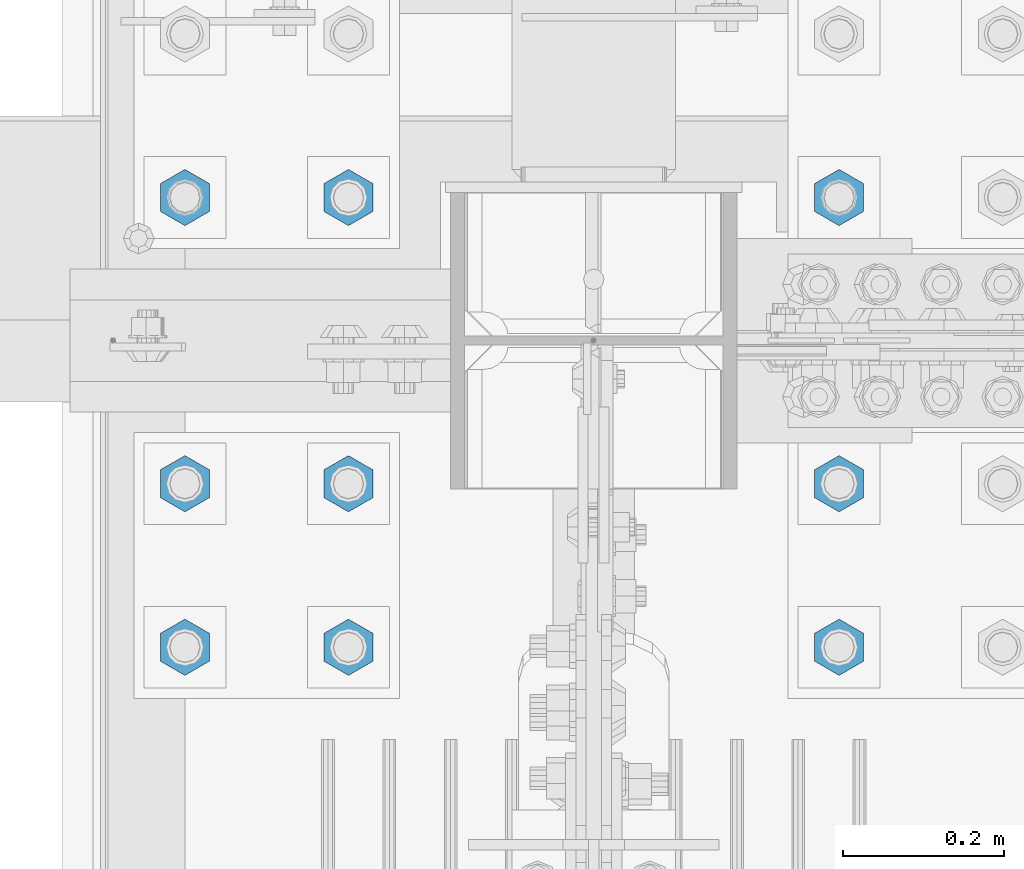
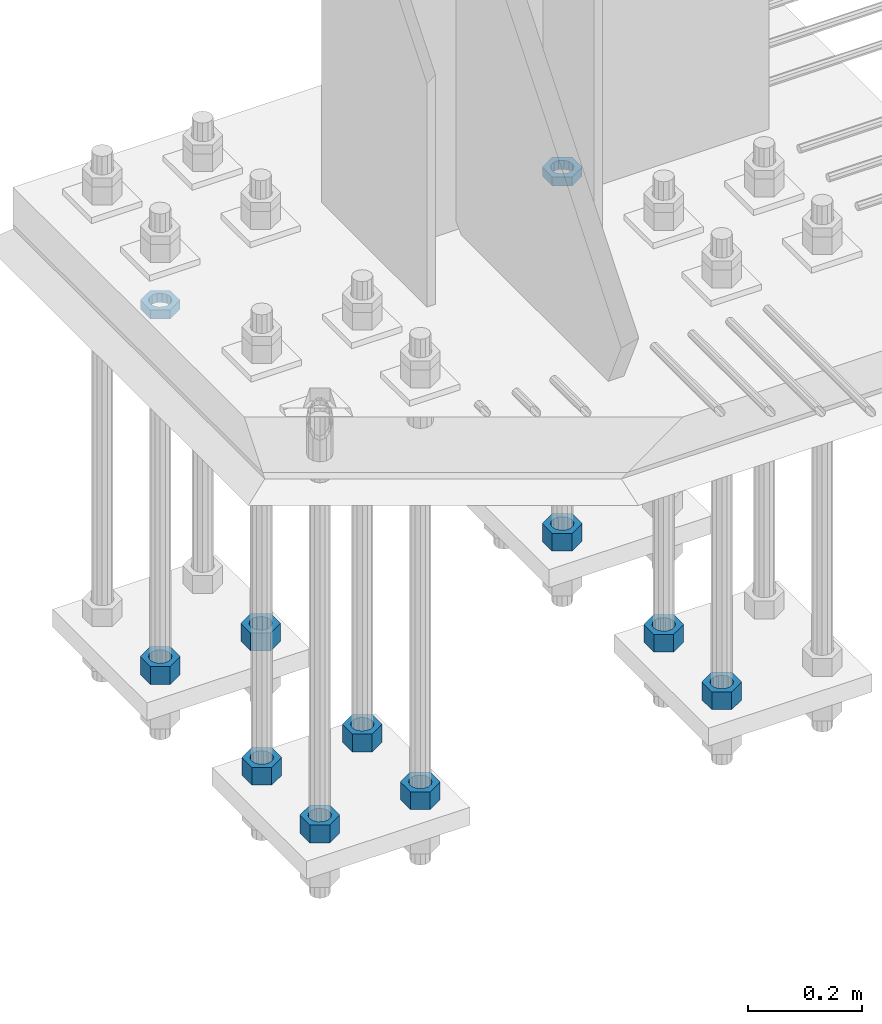
# One storey, part 2927 of 3843: 11 beams, 1 element without a shape of its own.
"""IFC2X3 building model written with IfcOpenShell, lengths in millimetres."""

from ifc_helpers import new_model, si_unit, frame, origin_with_axes, place, context, subcontext, project, spatial, faceted_brep, material, type_object, element, aggregate, save


model = new_model("IFC2X3")

# Units and contexts
model_context = context("Model", 3, precision=1e-05, world=origin_with_axes())
body_context = subcontext(model_context, "Body", "Model", "MODEL_VIEW")
ifc_project = project(units=[si_unit("LENGTHUNIT", "METRE", prefix="MILLI"), si_unit("AREAUNIT", "SQUARE_METRE"), si_unit("VOLUMEUNIT", "CUBIC_METRE"), si_unit("MASSUNIT", "GRAM", prefix="KILO"), si_unit("TIMEUNIT", "SECOND"), si_unit("PLANEANGLEUNIT", "RADIAN"), si_unit("SOLIDANGLEUNIT", "STERADIAN"), si_unit("THERMODYNAMICTEMPERATUREUNIT", "DEGREE_CELSIUS"), si_unit("LUMINOUSINTENSITYUNIT", "LUMEN")], contexts=[model_context])

# Site, building, storey
site_placement = place(None, origin_with_axes())
site = spatial("IfcSite", under=ifc_project, at=site_placement, CompositionType="ELEMENT")
building_placement = place(site_placement, origin_with_axes())
building = spatial("IfcBuilding", under=site, at=building_placement, Name="Undefined", CompositionType="ELEMENT")
storey_placement = place(building_placement, origin_with_axes())
storey = spatial("IfcBuildingStorey", under=building, at=storey_placement, Name="Undefined", CompositionType="ELEMENT", Elevation=0.0)

# Assembly, beams
assembly_placement = place(storey_placement, origin_with_axes())
assembly = element("IfcElementAssembly", 1, at=assembly_placement, inside=storey, Name="TEMPLATE", AssemblyPlace="NOTDEFINED", PredefinedType="RIGID_FRAME")
ifc_material = material(Name="STEEL/A572-50")
beam_type_1 = type_object("IfcBeamType", Name="1-1/2_HEAVY_HEX_NUT", PredefinedType="NOTDEFINED")
beam_1_placement = place(assembly_placement, frame((77317.6, 104736.9, 28841.7000015259), z_axis=(-1.0, 0.0, 0.0), x_axis=(0.0, 0.0, -1.0)))
beam_1 = element("IfcBeam", 2, at=beam_1_placement, type_object=beam_type_1, material=ifc_material, Name="NUT", ObjectType="1-1/2_HEAVY_HEX_NUT", context=body_context, shape_type="Brep", body=[
    faceted_brep([(0.0, -34.9199981689453, 0.0), (0.0, -17.4599990844727, -30.25), (38.0999999999985, -17.4599990844727, -30.25), (38.0999999999985, -34.9199981689453, 0.0), (0.0, 17.4599990844727, -30.25), (38.0999999999985, 17.4599990844727, -30.25), (0.0, 34.9199981689453, 0.0), (38.0999999999985, 34.9199981689453, 0.0), (0.0, 17.4599990844727, 30.25), (38.0999999999985, 17.4599990844727, 30.25), (0.0, -17.4599990844727, 30.25), (38.0999999999985, -17.4599990844727, 30.25), (0.0, 0.0, 20.6399993896484), (0.0, 8.9553601105581, 18.5959968835959), (38.0999999999985, 8.9553601105581, 18.5959968835959), (38.0999999999985, 0.0, 20.6399993896484), (0.0, 16.1370013209525, 12.8688291298167), (38.0999999999985, 16.1370013209525, 12.8688291298167), (0.0, 20.1225115123816, 4.59283194104501), (38.0999999999985, 20.1225115123816, 4.59283194104501), (0.0, 20.1225115123816, -4.59283194104501), (38.0999999999985, 20.1225115123816, -4.59283194104501), (0.0, 16.1370013209525, -12.8688291298167), (38.0999999999985, 16.1370013209525, -12.8688291298167), (0.0, 8.9553601105581, -18.5959968835959), (38.0999999999985, 8.9553601105581, -18.5959968835959), (0.0, 0.0, -20.6399993896484), (38.0999999999985, 0.0, -20.6399993896484), (0.0, -8.9553601105581, -18.5959968835959), (38.0999999999985, -8.9553601105581, -18.5959968835959), (0.0, -16.1370013209525, -12.8688291298167), (38.0999999999985, -16.1370013209525, -12.8688291298167), (0.0, -20.1225115123816, -4.59283194104501), (38.0999999999985, -20.1225115123816, -4.59283194104501), (0.0, -20.1225115123816, 4.59283194104501), (38.0999999999985, -20.1225115123816, 4.59283194104501), (0.0, -16.1370013209525, 12.8688291298167), (38.0999999999985, -16.1370013209525, 12.8688291298167), (0.0, -8.9553601105581, 18.5959968835959), (38.0999999999985, -8.9553601105581, 18.5959968835959)], [[[0, 1, 2, 3]], [[1, 4, 5, 2]], [[4, 6, 7, 5]], [[6, 8, 9, 7]], [[8, 10, 11, 9]], [[10, 0, 3, 11]], [[12, 13, 14, 15]], [[13, 16, 17, 14]], [[16, 18, 19, 17]], [[18, 20, 21, 19]], [[20, 22, 23, 21]], [[22, 24, 25, 23]], [[24, 26, 27, 25]], [[26, 28, 29, 27]], [[28, 30, 31, 29]], [[30, 32, 33, 31]], [[32, 34, 35, 33]], [[34, 36, 37, 35]], [[36, 38, 39, 37]], [[38, 12, 15, 39]], [[5, 7, 9, 11, 3, 2], [17, 19, 21, 23, 25, 27, 29, 31, 33, 35, 37, 39, 15, 14]], [[10, 8, 6, 4, 1, 0], [38, 36, 34, 32, 30, 28, 26, 24, 22, 20, 18, 16, 13, 12]]]),
])
beam_2_placement = place(assembly_placement, frame((76504.8, 104736.9, 28841.7000015259), z_axis=(-1.0, 0.0, 0.0), x_axis=(0.0, 0.0, -1.0)))
beam_2 = element("IfcBeam", 3, at=beam_2_placement, type_object=beam_type_1, material=ifc_material, Name="NUT", ObjectType="1-1/2_HEAVY_HEX_NUT", context=body_context, shape_type="Brep", body=[
    faceted_brep([(0.0, -34.9199981689453, 0.0), (0.0, -17.4599990844727, -30.25), (38.0999999999985, -17.4599990844727, -30.25), (38.0999999999985, -34.9199981689453, 0.0), (0.0, 17.4599990844727, -30.25), (38.0999999999985, 17.4599990844727, -30.25), (0.0, 34.9199981689453, 0.0), (38.0999999999985, 34.9199981689453, 0.0), (0.0, 17.4599990844727, 30.25), (38.0999999999985, 17.4599990844727, 30.25), (0.0, -17.4599990844727, 30.25), (38.0999999999985, -17.4599990844727, 30.25), (0.0, 0.0, 20.6399993896484), (0.0, 8.9553601105581, 18.5959968835959), (38.0999999999985, 8.9553601105581, 18.5959968835959), (38.0999999999985, 0.0, 20.6399993896484), (0.0, 16.1370013209525, 12.8688291298167), (38.0999999999985, 16.1370013209525, 12.8688291298167), (0.0, 20.1225115123816, 4.59283194104501), (38.0999999999985, 20.1225115123816, 4.59283194104501), (0.0, 20.1225115123816, -4.59283194104501), (38.0999999999985, 20.1225115123816, -4.59283194104501), (0.0, 16.1370013209525, -12.8688291298167), (38.0999999999985, 16.1370013209525, -12.8688291298167), (0.0, 8.9553601105581, -18.5959968835959), (38.0999999999985, 8.9553601105581, -18.5959968835959), (0.0, 0.0, -20.6399993896484), (38.0999999999985, 0.0, -20.6399993896484), (0.0, -8.9553601105581, -18.5959968835959), (38.0999999999985, -8.9553601105581, -18.5959968835959), (0.0, -16.1370013209525, -12.8688291298167), (38.0999999999985, -16.1370013209525, -12.8688291298167), (0.0, -20.1225115123816, -4.59283194104501), (38.0999999999985, -20.1225115123816, -4.59283194104501), (0.0, -20.1225115123816, 4.59283194104501), (38.0999999999985, -20.1225115123816, 4.59283194104501), (0.0, -16.1370013209525, 12.8688291298167), (38.0999999999985, -16.1370013209525, 12.8688291298167), (0.0, -8.9553601105581, 18.5959968835959), (38.0999999999985, -8.9553601105581, 18.5959968835959)], [[[0, 1, 2, 3]], [[1, 4, 5, 2]], [[4, 6, 7, 5]], [[6, 8, 9, 7]], [[8, 10, 11, 9]], [[10, 0, 3, 11]], [[12, 13, 14, 15]], [[13, 16, 17, 14]], [[16, 18, 19, 17]], [[18, 20, 21, 19]], [[20, 22, 23, 21]], [[22, 24, 25, 23]], [[24, 26, 27, 25]], [[26, 28, 29, 27]], [[28, 30, 31, 29]], [[30, 32, 33, 31]], [[32, 34, 35, 33]], [[34, 36, 37, 35]], [[36, 38, 39, 37]], [[38, 12, 15, 39]], [[5, 7, 9, 11, 3, 2], [17, 19, 21, 23, 25, 27, 29, 31, 33, 35, 37, 39, 15, 14]], [[10, 8, 6, 4, 1, 0], [38, 36, 34, 32, 30, 28, 26, 24, 22, 20, 18, 16, 13, 12]]]),
])
beam_3_placement = place(assembly_placement, frame((76708.0, 104736.9, 28841.7000015259), z_axis=(-1.0, 0.0, 0.0), x_axis=(0.0, 0.0, -1.0)))
beam_3 = element("IfcBeam", 4, at=beam_3_placement, type_object=beam_type_1, material=ifc_material, Name="NUT", ObjectType="1-1/2_HEAVY_HEX_NUT", context=body_context, shape_type="Brep", body=[
    faceted_brep([(0.0, -34.9199981689453, 0.0), (0.0, -17.4599990844727, -30.25), (38.0999999999985, -17.4599990844727, -30.25), (38.0999999999985, -34.9199981689453, 0.0), (0.0, 17.4599990844727, -30.25), (38.0999999999985, 17.4599990844727, -30.25), (0.0, 34.9199981689453, 0.0), (38.0999999999985, 34.9199981689453, 0.0), (0.0, 17.4599990844727, 30.25), (38.0999999999985, 17.4599990844727, 30.25), (0.0, -17.4599990844727, 30.25), (38.0999999999985, -17.4599990844727, 30.25), (0.0, 0.0, 20.6399993896484), (0.0, 8.9553601105581, 18.5959968835959), (38.0999999999985, 8.9553601105581, 18.5959968835959), (38.0999999999985, 0.0, 20.6399993896484), (0.0, 16.1370013209525, 12.8688291298167), (38.0999999999985, 16.1370013209525, 12.8688291298167), (0.0, 20.1225115123816, 4.59283194104501), (38.0999999999985, 20.1225115123816, 4.59283194104501), (0.0, 20.1225115123816, -4.59283194104501), (38.0999999999985, 20.1225115123816, -4.59283194104501), (0.0, 16.1370013209525, -12.8688291298167), (38.0999999999985, 16.1370013209525, -12.8688291298167), (0.0, 8.9553601105581, -18.5959968835959), (38.0999999999985, 8.9553601105581, -18.5959968835959), (0.0, 0.0, -20.6399993896484), (38.0999999999985, 0.0, -20.6399993896484), (0.0, -8.9553601105581, -18.5959968835959), (38.0999999999985, -8.9553601105581, -18.5959968835959), (0.0, -16.1370013209525, -12.8688291298167), (38.0999999999985, -16.1370013209525, -12.8688291298167), (0.0, -20.1225115123816, -4.59283194104501), (38.0999999999985, -20.1225115123816, -4.59283194104501), (0.0, -20.1225115123816, 4.59283194104501), (38.0999999999985, -20.1225115123816, 4.59283194104501), (0.0, -16.1370013209525, 12.8688291298167), (38.0999999999985, -16.1370013209525, 12.8688291298167), (0.0, -8.9553601105581, 18.5959968835959), (38.0999999999985, -8.9553601105581, 18.5959968835959)], [[[0, 1, 2, 3]], [[1, 4, 5, 2]], [[4, 6, 7, 5]], [[6, 8, 9, 7]], [[8, 10, 11, 9]], [[10, 0, 3, 11]], [[12, 13, 14, 15]], [[13, 16, 17, 14]], [[16, 18, 19, 17]], [[18, 20, 21, 19]], [[20, 22, 23, 21]], [[22, 24, 25, 23]], [[24, 26, 27, 25]], [[26, 28, 29, 27]], [[28, 30, 31, 29]], [[30, 32, 33, 31]], [[32, 34, 35, 33]], [[34, 36, 37, 35]], [[36, 38, 39, 37]], [[38, 12, 15, 39]], [[5, 7, 9, 11, 3, 2], [17, 19, 21, 23, 25, 27, 29, 31, 33, 35, 37, 39, 15, 14]], [[10, 8, 6, 4, 1, 0], [38, 36, 34, 32, 30, 28, 26, 24, 22, 20, 18, 16, 13, 12]]]),
])
beam_4_placement = place(assembly_placement, frame((76504.8, 104381.3, 28841.7000015259), z_axis=(1.0, 0.0, 0.0), x_axis=(0.0, 0.0, -1.0)))
beam_4 = element("IfcBeam", 5, at=beam_4_placement, type_object=beam_type_1, material=ifc_material, Name="NUT", ObjectType="1-1/2_HEAVY_HEX_NUT", context=body_context, shape_type="Brep", body=[
    faceted_brep([(0.0, -34.9199981689453, 0.0), (0.0, -17.4599990844727, -30.25), (38.0999999999985, -17.4599990844727, -30.25), (38.0999999999985, -34.9199981689453, 0.0), (0.0, 17.4599990844727, -30.25), (38.0999999999985, 17.4599990844727, -30.25), (0.0, 34.9199981689453, 0.0), (38.0999999999985, 34.9199981689453, 0.0), (0.0, 17.4599990844727, 30.25), (38.0999999999985, 17.4599990844727, 30.25), (0.0, -17.4599990844727, 30.25), (38.0999999999985, -17.4599990844727, 30.25), (0.0, 0.0, 20.6399993896484), (0.0, 8.9553601105581, 18.5959968835959), (38.0999999999985, 8.9553601105581, 18.5959968835959), (38.0999999999985, 0.0, 20.6399993896484), (0.0, 16.1370013209525, 12.8688291298167), (38.0999999999985, 16.1370013209525, 12.8688291298167), (0.0, 20.1225115123816, 4.59283194104501), (38.0999999999985, 20.1225115123816, 4.59283194104501), (0.0, 20.1225115123816, -4.59283194104501), (38.0999999999985, 20.1225115123816, -4.59283194104501), (0.0, 16.1370013209525, -12.8688291298167), (38.0999999999985, 16.1370013209525, -12.8688291298167), (0.0, 8.9553601105581, -18.5959968835959), (38.0999999999985, 8.9553601105581, -18.5959968835959), (0.0, 0.0, -20.6399993896484), (38.0999999999985, 0.0, -20.6399993896484), (0.0, -8.9553601105581, -18.5959968835959), (38.0999999999985, -8.9553601105581, -18.5959968835959), (0.0, -16.1370013209525, -12.8688291298167), (38.0999999999985, -16.1370013209525, -12.8688291298167), (0.0, -20.1225115123816, -4.59283194104501), (38.0999999999985, -20.1225115123816, -4.59283194104501), (0.0, -20.1225115123816, 4.59283194104501), (38.0999999999985, -20.1225115123816, 4.59283194104501), (0.0, -16.1370013209525, 12.8688291298167), (38.0999999999985, -16.1370013209525, 12.8688291298167), (0.0, -8.9553601105581, 18.5959968835959), (38.0999999999985, -8.9553601105581, 18.5959968835959)], [[[0, 1, 2, 3]], [[1, 4, 5, 2]], [[4, 6, 7, 5]], [[6, 8, 9, 7]], [[8, 10, 11, 9]], [[10, 0, 3, 11]], [[12, 13, 14, 15]], [[13, 16, 17, 14]], [[16, 18, 19, 17]], [[18, 20, 21, 19]], [[20, 22, 23, 21]], [[22, 24, 25, 23]], [[24, 26, 27, 25]], [[26, 28, 29, 27]], [[28, 30, 31, 29]], [[30, 32, 33, 31]], [[32, 34, 35, 33]], [[34, 36, 37, 35]], [[36, 38, 39, 37]], [[38, 12, 15, 39]], [[5, 7, 9, 11, 3, 2], [17, 19, 21, 23, 25, 27, 29, 31, 33, 35, 37, 39, 15, 14]], [[10, 8, 6, 4, 1, 0], [38, 36, 34, 32, 30, 28, 26, 24, 22, 20, 18, 16, 13, 12]]]),
])
beam_5_placement = place(assembly_placement, frame((76504.8, 104178.1, 28841.7000015259), z_axis=(1.0, 0.0, 0.0), x_axis=(0.0, 0.0, -1.0)))
beam_5 = element("IfcBeam", 6, at=beam_5_placement, type_object=beam_type_1, material=ifc_material, Name="NUT", ObjectType="1-1/2_HEAVY_HEX_NUT", context=body_context, shape_type="Brep", body=[
    faceted_brep([(0.0, -34.9199981689453, 0.0), (0.0, -17.4599990844727, -30.25), (38.0999999999985, -17.4599990844727, -30.25), (38.0999999999985, -34.9199981689453, 0.0), (0.0, 17.4599990844727, -30.25), (38.0999999999985, 17.4599990844727, -30.25), (0.0, 34.9199981689453, 0.0), (38.0999999999985, 34.9199981689453, 0.0), (0.0, 17.4599990844727, 30.25), (38.0999999999985, 17.4599990844727, 30.25), (0.0, -17.4599990844727, 30.25), (38.0999999999985, -17.4599990844727, 30.25), (0.0, 0.0, 20.6399993896484), (0.0, 8.9553601105581, 18.5959968835959), (38.0999999999985, 8.9553601105581, 18.5959968835959), (38.0999999999985, 0.0, 20.6399993896484), (0.0, 16.1370013209525, 12.8688291298167), (38.0999999999985, 16.1370013209525, 12.8688291298167), (0.0, 20.1225115123816, 4.59283194104501), (38.0999999999985, 20.1225115123816, 4.59283194104501), (0.0, 20.1225115123816, -4.59283194104501), (38.0999999999985, 20.1225115123816, -4.59283194104501), (0.0, 16.1370013209525, -12.8688291298167), (38.0999999999985, 16.1370013209525, -12.8688291298167), (0.0, 8.9553601105581, -18.5959968835959), (38.0999999999985, 8.9553601105581, -18.5959968835959), (0.0, 0.0, -20.6399993896484), (38.0999999999985, 0.0, -20.6399993896484), (0.0, -8.9553601105581, -18.5959968835959), (38.0999999999985, -8.9553601105581, -18.5959968835959), (0.0, -16.1370013209525, -12.8688291298167), (38.0999999999985, -16.1370013209525, -12.8688291298167), (0.0, -20.1225115123816, -4.59283194104501), (38.0999999999985, -20.1225115123816, -4.59283194104501), (0.0, -20.1225115123816, 4.59283194104501), (38.0999999999985, -20.1225115123816, 4.59283194104501), (0.0, -16.1370013209525, 12.8688291298167), (38.0999999999985, -16.1370013209525, 12.8688291298167), (0.0, -8.9553601105581, 18.5959968835959), (38.0999999999985, -8.9553601105581, 18.5959968835959)], [[[0, 1, 2, 3]], [[1, 4, 5, 2]], [[4, 6, 7, 5]], [[6, 8, 9, 7]], [[8, 10, 11, 9]], [[10, 0, 3, 11]], [[12, 13, 14, 15]], [[13, 16, 17, 14]], [[16, 18, 19, 17]], [[18, 20, 21, 19]], [[20, 22, 23, 21]], [[22, 24, 25, 23]], [[24, 26, 27, 25]], [[26, 28, 29, 27]], [[28, 30, 31, 29]], [[30, 32, 33, 31]], [[32, 34, 35, 33]], [[34, 36, 37, 35]], [[36, 38, 39, 37]], [[38, 12, 15, 39]], [[5, 7, 9, 11, 3, 2], [17, 19, 21, 23, 25, 27, 29, 31, 33, 35, 37, 39, 15, 14]], [[10, 8, 6, 4, 1, 0], [38, 36, 34, 32, 30, 28, 26, 24, 22, 20, 18, 16, 13, 12]]]),
])
beam_6_placement = place(assembly_placement, frame((76708.0, 104381.3, 28841.7000015259), z_axis=(1.0, 0.0, 0.0), x_axis=(0.0, 0.0, -1.0)))
beam_6 = element("IfcBeam", 7, at=beam_6_placement, type_object=beam_type_1, material=ifc_material, Name="NUT", ObjectType="1-1/2_HEAVY_HEX_NUT", context=body_context, shape_type="Brep", body=[
    faceted_brep([(0.0, -34.9199981689453, 0.0), (0.0, -17.4599990844727, -30.25), (38.0999999999985, -17.4599990844727, -30.25), (38.0999999999985, -34.9199981689453, 0.0), (0.0, 17.4599990844727, -30.25), (38.0999999999985, 17.4599990844727, -30.25), (0.0, 34.9199981689453, 0.0), (38.0999999999985, 34.9199981689453, 0.0), (0.0, 17.4599990844727, 30.25), (38.0999999999985, 17.4599990844727, 30.25), (0.0, -17.4599990844727, 30.25), (38.0999999999985, -17.4599990844727, 30.25), (0.0, 0.0, 20.6399993896484), (0.0, 8.9553601105581, 18.5959968835959), (38.0999999999985, 8.9553601105581, 18.5959968835959), (38.0999999999985, 0.0, 20.6399993896484), (0.0, 16.1370013209525, 12.8688291298167), (38.0999999999985, 16.1370013209525, 12.8688291298167), (0.0, 20.1225115123816, 4.59283194104501), (38.0999999999985, 20.1225115123816, 4.59283194104501), (0.0, 20.1225115123816, -4.59283194104501), (38.0999999999985, 20.1225115123816, -4.59283194104501), (0.0, 16.1370013209525, -12.8688291298167), (38.0999999999985, 16.1370013209525, -12.8688291298167), (0.0, 8.9553601105581, -18.5959968835959), (38.0999999999985, 8.9553601105581, -18.5959968835959), (0.0, 0.0, -20.6399993896484), (38.0999999999985, 0.0, -20.6399993896484), (0.0, -8.9553601105581, -18.5959968835959), (38.0999999999985, -8.9553601105581, -18.5959968835959), (0.0, -16.1370013209525, -12.8688291298167), (38.0999999999985, -16.1370013209525, -12.8688291298167), (0.0, -20.1225115123816, -4.59283194104501), (38.0999999999985, -20.1225115123816, -4.59283194104501), (0.0, -20.1225115123816, 4.59283194104501), (38.0999999999985, -20.1225115123816, 4.59283194104501), (0.0, -16.1370013209525, 12.8688291298167), (38.0999999999985, -16.1370013209525, 12.8688291298167), (0.0, -8.9553601105581, 18.5959968835959), (38.0999999999985, -8.9553601105581, 18.5959968835959)], [[[0, 1, 2, 3]], [[1, 4, 5, 2]], [[4, 6, 7, 5]], [[6, 8, 9, 7]], [[8, 10, 11, 9]], [[10, 0, 3, 11]], [[12, 13, 14, 15]], [[13, 16, 17, 14]], [[16, 18, 19, 17]], [[18, 20, 21, 19]], [[20, 22, 23, 21]], [[22, 24, 25, 23]], [[24, 26, 27, 25]], [[26, 28, 29, 27]], [[28, 30, 31, 29]], [[30, 32, 33, 31]], [[32, 34, 35, 33]], [[34, 36, 37, 35]], [[36, 38, 39, 37]], [[38, 12, 15, 39]], [[5, 7, 9, 11, 3, 2], [17, 19, 21, 23, 25, 27, 29, 31, 33, 35, 37, 39, 15, 14]], [[10, 8, 6, 4, 1, 0], [38, 36, 34, 32, 30, 28, 26, 24, 22, 20, 18, 16, 13, 12]]]),
])
beam_7_placement = place(assembly_placement, frame((76708.0, 104178.1, 28841.7000015259), z_axis=(1.0, 0.0, 0.0), x_axis=(0.0, 0.0, -1.0)))
beam_7 = element("IfcBeam", 8, at=beam_7_placement, type_object=beam_type_1, material=ifc_material, Name="NUT", ObjectType="1-1/2_HEAVY_HEX_NUT", context=body_context, shape_type="Brep", body=[
    faceted_brep([(0.0, -34.9199981689453, 0.0), (0.0, -17.4599990844727, -30.25), (38.0999999999985, -17.4599990844727, -30.25), (38.0999999999985, -34.9199981689453, 0.0), (0.0, 17.4599990844727, -30.25), (38.0999999999985, 17.4599990844727, -30.25), (0.0, 34.9199981689453, 0.0), (38.0999999999985, 34.9199981689453, 0.0), (0.0, 17.4599990844727, 30.25), (38.0999999999985, 17.4599990844727, 30.25), (0.0, -17.4599990844727, 30.25), (38.0999999999985, -17.4599990844727, 30.25), (0.0, 0.0, 20.6399993896484), (0.0, 8.9553601105581, 18.5959968835959), (38.0999999999985, 8.9553601105581, 18.5959968835959), (38.0999999999985, 0.0, 20.6399993896484), (0.0, 16.1370013209525, 12.8688291298167), (38.0999999999985, 16.1370013209525, 12.8688291298167), (0.0, 20.1225115123816, 4.59283194104501), (38.0999999999985, 20.1225115123816, 4.59283194104501), (0.0, 20.1225115123816, -4.59283194104501), (38.0999999999985, 20.1225115123816, -4.59283194104501), (0.0, 16.1370013209525, -12.8688291298167), (38.0999999999985, 16.1370013209525, -12.8688291298167), (0.0, 8.9553601105581, -18.5959968835959), (38.0999999999985, 8.9553601105581, -18.5959968835959), (0.0, 0.0, -20.6399993896484), (38.0999999999985, 0.0, -20.6399993896484), (0.0, -8.9553601105581, -18.5959968835959), (38.0999999999985, -8.9553601105581, -18.5959968835959), (0.0, -16.1370013209525, -12.8688291298167), (38.0999999999985, -16.1370013209525, -12.8688291298167), (0.0, -20.1225115123816, -4.59283194104501), (38.0999999999985, -20.1225115123816, -4.59283194104501), (0.0, -20.1225115123816, 4.59283194104501), (38.0999999999985, -20.1225115123816, 4.59283194104501), (0.0, -16.1370013209525, 12.8688291298167), (38.0999999999985, -16.1370013209525, 12.8688291298167), (0.0, -8.9553601105581, 18.5959968835959), (38.0999999999985, -8.9553601105581, 18.5959968835959)], [[[0, 1, 2, 3]], [[1, 4, 5, 2]], [[4, 6, 7, 5]], [[6, 8, 9, 7]], [[8, 10, 11, 9]], [[10, 0, 3, 11]], [[12, 13, 14, 15]], [[13, 16, 17, 14]], [[16, 18, 19, 17]], [[18, 20, 21, 19]], [[20, 22, 23, 21]], [[22, 24, 25, 23]], [[24, 26, 27, 25]], [[26, 28, 29, 27]], [[28, 30, 31, 29]], [[30, 32, 33, 31]], [[32, 34, 35, 33]], [[34, 36, 37, 35]], [[36, 38, 39, 37]], [[38, 12, 15, 39]], [[5, 7, 9, 11, 3, 2], [17, 19, 21, 23, 25, 27, 29, 31, 33, 35, 37, 39, 15, 14]], [[10, 8, 6, 4, 1, 0], [38, 36, 34, 32, 30, 28, 26, 24, 22, 20, 18, 16, 13, 12]]]),
])
beam_8_placement = place(assembly_placement, frame((77317.6, 104381.3, 28841.7000015259), z_axis=(1.0, 0.0, 0.0), x_axis=(0.0, 0.0, -1.0)))
beam_8 = element("IfcBeam", 9, at=beam_8_placement, type_object=beam_type_1, material=ifc_material, Name="NUT", ObjectType="1-1/2_HEAVY_HEX_NUT", context=body_context, shape_type="Brep", body=[
    faceted_brep([(0.0, -34.9199981689453, 0.0), (0.0, -17.4599990844727, -30.25), (38.0999999999985, -17.4599990844727, -30.25), (38.0999999999985, -34.9199981689453, 0.0), (0.0, 17.4599990844727, -30.25), (38.0999999999985, 17.4599990844727, -30.25), (0.0, 34.9199981689453, 0.0), (38.0999999999985, 34.9199981689453, 0.0), (0.0, 17.4599990844727, 30.25), (38.0999999999985, 17.4599990844727, 30.25), (0.0, -17.4599990844727, 30.25), (38.0999999999985, -17.4599990844727, 30.25), (0.0, 0.0, 20.6399993896484), (0.0, 8.9553601105581, 18.5959968835959), (38.0999999999985, 8.9553601105581, 18.5959968835959), (38.0999999999985, 0.0, 20.6399993896484), (0.0, 16.1370013209525, 12.8688291298167), (38.0999999999985, 16.1370013209525, 12.8688291298167), (0.0, 20.1225115123816, 4.59283194104501), (38.0999999999985, 20.1225115123816, 4.59283194104501), (0.0, 20.1225115123816, -4.59283194104501), (38.0999999999985, 20.1225115123816, -4.59283194104501), (0.0, 16.1370013209525, -12.8688291298167), (38.0999999999985, 16.1370013209525, -12.8688291298167), (0.0, 8.9553601105581, -18.5959968835959), (38.0999999999985, 8.9553601105581, -18.5959968835959), (0.0, 0.0, -20.6399993896484), (38.0999999999985, 0.0, -20.6399993896484), (0.0, -8.9553601105581, -18.5959968835959), (38.0999999999985, -8.9553601105581, -18.5959968835959), (0.0, -16.1370013209525, -12.8688291298167), (38.0999999999985, -16.1370013209525, -12.8688291298167), (0.0, -20.1225115123816, -4.59283194104501), (38.0999999999985, -20.1225115123816, -4.59283194104501), (0.0, -20.1225115123816, 4.59283194104501), (38.0999999999985, -20.1225115123816, 4.59283194104501), (0.0, -16.1370013209525, 12.8688291298167), (38.0999999999985, -16.1370013209525, 12.8688291298167), (0.0, -8.9553601105581, 18.5959968835959), (38.0999999999985, -8.9553601105581, 18.5959968835959)], [[[0, 1, 2, 3]], [[1, 4, 5, 2]], [[4, 6, 7, 5]], [[6, 8, 9, 7]], [[8, 10, 11, 9]], [[10, 0, 3, 11]], [[12, 13, 14, 15]], [[13, 16, 17, 14]], [[16, 18, 19, 17]], [[18, 20, 21, 19]], [[20, 22, 23, 21]], [[22, 24, 25, 23]], [[24, 26, 27, 25]], [[26, 28, 29, 27]], [[28, 30, 31, 29]], [[30, 32, 33, 31]], [[32, 34, 35, 33]], [[34, 36, 37, 35]], [[36, 38, 39, 37]], [[38, 12, 15, 39]], [[5, 7, 9, 11, 3, 2], [17, 19, 21, 23, 25, 27, 29, 31, 33, 35, 37, 39, 15, 14]], [[10, 8, 6, 4, 1, 0], [38, 36, 34, 32, 30, 28, 26, 24, 22, 20, 18, 16, 13, 12]]]),
])
beam_9_placement = place(assembly_placement, frame((77317.6, 104178.1, 28841.7000015259), z_axis=(1.0, 0.0, 0.0), x_axis=(0.0, 0.0, -1.0)))
beam_9 = element("IfcBeam", 10, at=beam_9_placement, type_object=beam_type_1, material=ifc_material, Name="NUT", ObjectType="1-1/2_HEAVY_HEX_NUT", context=body_context, shape_type="Brep", body=[
    faceted_brep([(0.0, -34.9199981689453, 0.0), (0.0, -17.4599990844727, -30.25), (38.0999999999985, -17.4599990844727, -30.25), (38.0999999999985, -34.9199981689453, 0.0), (0.0, 17.4599990844727, -30.25), (38.0999999999985, 17.4599990844727, -30.25), (0.0, 34.9199981689453, 0.0), (38.0999999999985, 34.9199981689453, 0.0), (0.0, 17.4599990844727, 30.25), (38.0999999999985, 17.4599990844727, 30.25), (0.0, -17.4599990844727, 30.25), (38.0999999999985, -17.4599990844727, 30.25), (0.0, 0.0, 20.6399993896484), (0.0, 8.9553601105581, 18.5959968835959), (38.0999999999985, 8.9553601105581, 18.5959968835959), (38.0999999999985, 0.0, 20.6399993896484), (0.0, 16.1370013209525, 12.8688291298167), (38.0999999999985, 16.1370013209525, 12.8688291298167), (0.0, 20.1225115123816, 4.59283194104501), (38.0999999999985, 20.1225115123816, 4.59283194104501), (0.0, 20.1225115123816, -4.59283194104501), (38.0999999999985, 20.1225115123816, -4.59283194104501), (0.0, 16.1370013209525, -12.8688291298167), (38.0999999999985, 16.1370013209525, -12.8688291298167), (0.0, 8.9553601105581, -18.5959968835959), (38.0999999999985, 8.9553601105581, -18.5959968835959), (0.0, 0.0, -20.6399993896484), (38.0999999999985, 0.0, -20.6399993896484), (0.0, -8.9553601105581, -18.5959968835959), (38.0999999999985, -8.9553601105581, -18.5959968835959), (0.0, -16.1370013209525, -12.8688291298167), (38.0999999999985, -16.1370013209525, -12.8688291298167), (0.0, -20.1225115123816, -4.59283194104501), (38.0999999999985, -20.1225115123816, -4.59283194104501), (0.0, -20.1225115123816, 4.59283194104501), (38.0999999999985, -20.1225115123816, 4.59283194104501), (0.0, -16.1370013209525, 12.8688291298167), (38.0999999999985, -16.1370013209525, 12.8688291298167), (0.0, -8.9553601105581, 18.5959968835959), (38.0999999999985, -8.9553601105581, 18.5959968835959)], [[[0, 1, 2, 3]], [[1, 4, 5, 2]], [[4, 6, 7, 5]], [[6, 8, 9, 7]], [[8, 10, 11, 9]], [[10, 0, 3, 11]], [[12, 13, 14, 15]], [[13, 16, 17, 14]], [[16, 18, 19, 17]], [[18, 20, 21, 19]], [[20, 22, 23, 21]], [[22, 24, 25, 23]], [[24, 26, 27, 25]], [[26, 28, 29, 27]], [[28, 30, 31, 29]], [[30, 32, 33, 31]], [[32, 34, 35, 33]], [[34, 36, 37, 35]], [[36, 38, 39, 37]], [[38, 12, 15, 39]], [[5, 7, 9, 11, 3, 2], [17, 19, 21, 23, 25, 27, 29, 31, 33, 35, 37, 39, 15, 14]], [[10, 8, 6, 4, 1, 0], [38, 36, 34, 32, 30, 28, 26, 24, 22, 20, 18, 16, 13, 12]]]),
])
beam_type_2 = type_object("IfcBeamType", Name="1-1/2_HALF_NUT", PredefinedType="NOTDEFINED")
beam_10_placement = place(assembly_placement, frame((77317.6, 104736.9, 29603.7), z_axis=(-1.0, 0.0, 0.0), x_axis=(0.0, 0.0, -1.0)))
beam_10 = element("IfcBeam", 11, at=beam_10_placement, type_object=beam_type_2, material=ifc_material, Name="NUT", ObjectType="1-1/2_HALF_NUT", context=body_context, shape_type="Brep", body=[
    faceted_brep([(0.0, -34.9199981689453, 0.0), (0.0, -17.4599990844727, -30.25), (19.0500000000029, -17.4599990844727, -30.25), (19.0500000000029, -34.9199981689453, 0.0), (0.0, 17.4599990844727, -30.25), (19.0500000000029, 17.4599990844727, -30.25), (0.0, 34.9199981689453, 0.0), (19.0500000000029, 34.9199981689453, 0.0), (0.0, 17.4599990844727, 30.25), (19.0500000000029, 17.4599990844727, 30.25), (0.0, -17.4599990844727, 30.25), (19.0500000000029, -17.4599990844727, 30.25), (0.0, 0.0, 20.6399993896484), (0.0, 8.9553601105581, 18.5959968835959), (19.0500000000029, 8.95536011056538, 18.5959968835959), (19.0500000000029, 0.0, 20.6399993896484), (0.0, 16.1370013209525, 12.8688291298167), (19.0500000000029, 16.1370013209489, 12.8688291298167), (0.0, 20.1225115123816, 4.59283194104501), (19.0500000000029, 20.1225115123852, 4.59283194104501), (0.0, 20.1225115123816, -4.59283194104501), (19.0500000000029, 20.1225115123852, -4.59283194104501), (0.0, 16.1370013209525, -12.8688291298167), (19.0500000000029, 16.1370013209489, -12.8688291298167), (0.0, 8.9553601105581, -18.5959968835959), (19.0500000000029, 8.95536011056538, -18.5959968835959), (0.0, 0.0, -20.6399993896484), (19.0500000000029, 0.0, -20.6399993896484), (0.0, -8.9553601105581, -18.5959968835959), (19.0500000000029, -8.95536011056538, -18.5959968835959), (0.0, -16.1370013209525, -12.8688291298167), (19.0500000000029, -16.1370013209489, -12.8688291298167), (0.0, -20.1225115123816, -4.59283194104501), (19.0500000000029, -20.1225115123852, -4.59283194104501), (0.0, -20.1225115123816, 4.59283194104501), (19.0500000000029, -20.1225115123852, 4.59283194104501), (0.0, -16.1370013209525, 12.8688291298167), (19.0500000000029, -16.1370013209489, 12.8688291298167), (0.0, -8.9553601105581, 18.5959968835959), (19.0500000000029, -8.95536011056538, 18.5959968835959)], [[[0, 1, 2, 3]], [[1, 4, 5, 2]], [[4, 6, 7, 5]], [[6, 8, 9, 7]], [[8, 10, 11, 9]], [[10, 0, 3, 11]], [[12, 13, 14, 15]], [[13, 16, 17, 14]], [[16, 18, 19, 17]], [[18, 20, 21, 19]], [[20, 22, 23, 21]], [[22, 24, 25, 23]], [[24, 26, 27, 25]], [[26, 28, 29, 27]], [[28, 30, 31, 29]], [[30, 32, 33, 31]], [[32, 34, 35, 33]], [[34, 36, 37, 35]], [[36, 38, 39, 37]], [[38, 12, 15, 39]], [[5, 7, 9, 11, 3, 2], [17, 19, 21, 23, 25, 27, 29, 31, 33, 35, 37, 39, 15, 14]], [[10, 8, 6, 4, 1, 0], [38, 36, 34, 32, 30, 28, 26, 24, 22, 20, 18, 16, 13, 12]]]),
])
beam_11_placement = place(assembly_placement, frame((76504.8, 104736.9, 29603.7), z_axis=(-1.0, 0.0, 0.0), x_axis=(0.0, 0.0, -1.0)))
beam_11 = element("IfcBeam", 12, at=beam_11_placement, type_object=beam_type_2, material=ifc_material, Name="NUT", ObjectType="1-1/2_HALF_NUT", context=body_context, shape_type="Brep", body=[
    faceted_brep([(0.0, -34.9199981689453, 0.0), (0.0, -17.4599990844727, -30.25), (19.0500000000029, -17.4599990844727, -30.25), (19.0500000000029, -34.9199981689453, 0.0), (0.0, 17.4599990844727, -30.25), (19.0500000000029, 17.4599990844727, -30.25), (0.0, 34.9199981689453, 0.0), (19.0500000000029, 34.9199981689453, 0.0), (0.0, 17.4599990844727, 30.25), (19.0500000000029, 17.4599990844727, 30.25), (0.0, -17.4599990844727, 30.25), (19.0500000000029, -17.4599990844727, 30.25), (0.0, 0.0, 20.6399993896484), (0.0, 8.9553601105581, 18.5959968835959), (19.0500000000029, 8.95536011056538, 18.5959968835959), (19.0500000000029, 0.0, 20.6399993896484), (0.0, 16.1370013209525, 12.8688291298167), (19.0500000000029, 16.1370013209489, 12.8688291298167), (0.0, 20.1225115123816, 4.59283194104501), (19.0500000000029, 20.1225115123852, 4.59283194104501), (0.0, 20.1225115123816, -4.59283194104501), (19.0500000000029, 20.1225115123852, -4.59283194104501), (0.0, 16.1370013209525, -12.8688291298167), (19.0500000000029, 16.1370013209489, -12.8688291298167), (0.0, 8.9553601105581, -18.5959968835959), (19.0500000000029, 8.95536011056538, -18.5959968835959), (0.0, 0.0, -20.6399993896484), (19.0500000000029, 0.0, -20.6399993896484), (0.0, -8.9553601105581, -18.5959968835959), (19.0500000000029, -8.95536011056538, -18.5959968835959), (0.0, -16.1370013209525, -12.8688291298167), (19.0500000000029, -16.1370013209489, -12.8688291298167), (0.0, -20.1225115123816, -4.59283194104501), (19.0500000000029, -20.1225115123852, -4.59283194104501), (0.0, -20.1225115123816, 4.59283194104501), (19.0500000000029, -20.1225115123852, 4.59283194104501), (0.0, -16.1370013209525, 12.8688291298167), (19.0500000000029, -16.1370013209489, 12.8688291298167), (0.0, -8.9553601105581, 18.5959968835959), (19.0500000000029, -8.95536011056538, 18.5959968835959)], [[[0, 1, 2, 3]], [[1, 4, 5, 2]], [[4, 6, 7, 5]], [[6, 8, 9, 7]], [[8, 10, 11, 9]], [[10, 0, 3, 11]], [[12, 13, 14, 15]], [[13, 16, 17, 14]], [[16, 18, 19, 17]], [[18, 20, 21, 19]], [[20, 22, 23, 21]], [[22, 24, 25, 23]], [[24, 26, 27, 25]], [[26, 28, 29, 27]], [[28, 30, 31, 29]], [[30, 32, 33, 31]], [[32, 34, 35, 33]], [[34, 36, 37, 35]], [[36, 38, 39, 37]], [[38, 12, 15, 39]], [[5, 7, 9, 11, 3, 2], [17, 19, 21, 23, 25, 27, 29, 31, 33, 35, 37, 39, 15, 14]], [[10, 8, 6, 4, 1, 0], [38, 36, 34, 32, 30, 28, 26, 24, 22, 20, 18, 16, 13, 12]]]),
])
aggregate(assembly, [beam_1, beam_2, beam_3, beam_4, beam_5, beam_6, beam_7, beam_8, beam_9, beam_10, beam_11])

save(model, "model.ifc")
